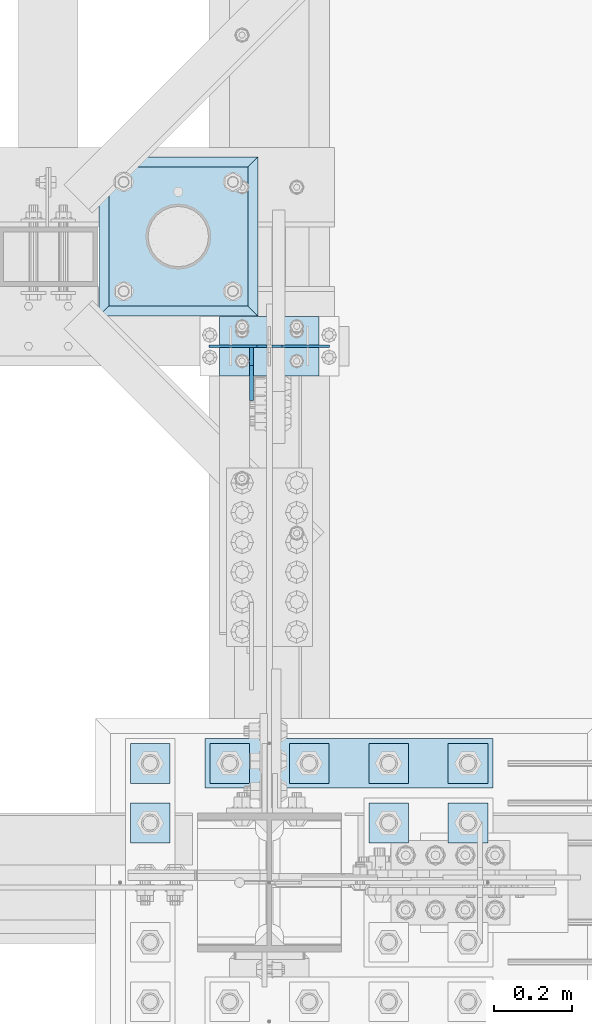
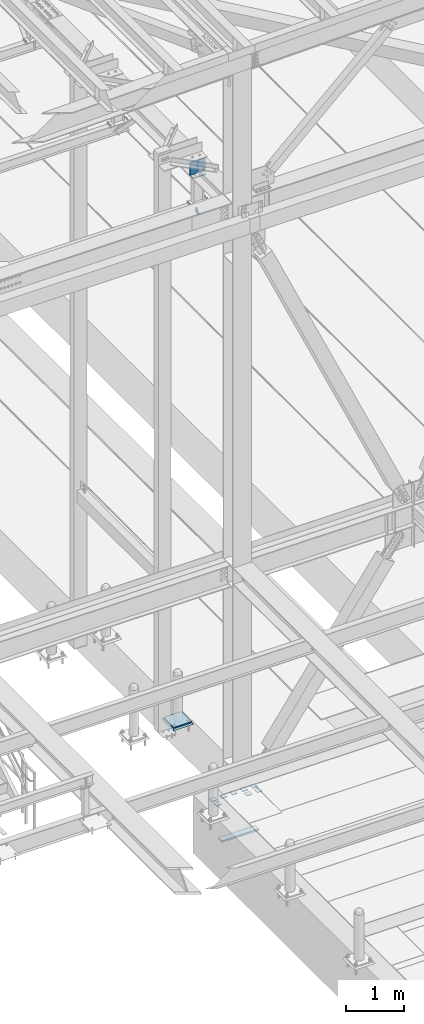
# One storey, part 3035 of 3843: 15 plates, 6 elements without a shape of their own.
"""IFC2X3 building model written with IfcOpenShell, lengths in millimetres."""

from ifc_helpers import new_model, si_unit, frame, origin_with_axes, place, context, subcontext, project, spatial, faceted_brep, material, type_object, element, aggregate, save


model = new_model("IFC2X3")

# Units and contexts
model_context = context("Model", 3, precision=1e-05, world=origin_with_axes())
body_context = subcontext(model_context, "Body", "Model", "MODEL_VIEW")
ifc_project = project(units=[si_unit("LENGTHUNIT", "METRE", prefix="MILLI"), si_unit("AREAUNIT", "SQUARE_METRE"), si_unit("VOLUMEUNIT", "CUBIC_METRE"), si_unit("MASSUNIT", "GRAM", prefix="KILO"), si_unit("TIMEUNIT", "SECOND"), si_unit("PLANEANGLEUNIT", "RADIAN"), si_unit("SOLIDANGLEUNIT", "STERADIAN"), si_unit("THERMODYNAMICTEMPERATUREUNIT", "DEGREE_CELSIUS"), si_unit("LUMINOUSINTENSITYUNIT", "LUMEN")], contexts=[model_context])

# Site, building, storey
site_placement = place(None, origin_with_axes())
site = spatial("IfcSite", under=ifc_project, at=site_placement, CompositionType="ELEMENT")
building_placement = place(site_placement, origin_with_axes())
building = spatial("IfcBuilding", under=site, at=building_placement, Name="Undefined", CompositionType="ELEMENT")
storey_placement = place(building_placement, origin_with_axes())
storey = spatial("IfcBuildingStorey", under=building, at=storey_placement, Name="Undefined", CompositionType="ELEMENT", Elevation=0.0)

# Assembly, plate
assembly_1_placement = place(storey_placement, origin_with_axes())
assembly_1 = element("IfcElementAssembly", 1, at=assembly_1_placement, inside=storey, Name="PIPE_BOLLARD", AssemblyPlace="NOTDEFINED", PredefinedType="RIGID_FRAME")
ifc_material_1 = material(Name="STEEL/A572-50")
plate_type_1 = type_object("IfcPlateType", PredefinedType="NOTDEFINED")
plate_1_placement = place(assembly_1_placement, frame((41651.6014282227, 27089.8153033043, 30518.1), z_axis=(0.0, 1.0, 0.0), x_axis=(1.0, 0.0, 0.0)))
plate_1 = element("IfcPlate", 2, at=plate_1_placement, type_object=plate_type_1, material=ifc_material_1, Name="PLATE", context=body_context, shape_type="Brep", body=[
    faceted_brep([(0.0, -12.6999999999971, 0.0), (0.0, -12.7000000000007, 355.600000000006), (0.0, 12.7000000000007, 355.600000000006), (0.0, 12.6999999999971, 0.0), (355.599999999999, -12.7000000000007, 355.600000000006), (355.599999999999, 12.7000000000007, 355.600000000006), (355.599999999999, -12.7000000000007, 0.0), (355.599999999999, 12.7000000000007, 0.0)], [[[0, 1, 2, 3]], [[1, 4, 5, 2]], [[4, 6, 7, 5]], [[6, 0, 3, 7]], [[5, 7, 3, 2]], [[6, 4, 1, 0]]]),
])
aggregate(assembly_1, [plate_1])

assembly_2_placement = place(storey_placement, origin_with_axes())
assembly_2 = element("IfcElementAssembly", 3, at=assembly_2_placement, inside=storey, Name="GROUT", AssemblyPlace="NOTDEFINED", PredefinedType="REINFORCEMENT_UNIT")
ifc_material_2 = material(Name="CONCRETE/Concrete_Undefined")
plate_type_2 = type_object("IfcPlateType", PredefinedType="NOTDEFINED")
plate_2_placement = place(assembly_2_placement, frame((41626.2014282227, 27064.4153033043, 30492.7), z_axis=(0.0, 1.0, 0.0), x_axis=(1.0, 0.0, 0.0)))
plate_2 = element("IfcPlate", 4, at=plate_2_placement, type_object=plate_type_2, material=ifc_material_2, Name="GROUT", context=body_context, shape_type="Brep", body=[
    faceted_brep([(25.4000000001906, -12.6999999998552, 380.999999999505), (0.0, 12.7000000000007, 406.399999999994), (0.0, 12.6999999999971, 0.0), (25.4000000001906, -12.6999999999898, 25.4000000004453), (380.999999999833, -12.6999999998588, 25.4000000004453), (406.400000000001, 12.7000000000007, 0.0), (406.400000000001, 12.7000000000007, 406.399999999994), (380.999999999833, -12.6999999999898, 380.999999999505)], [[[0, 1, 2, 3]], [[4, 5, 6, 7]], [[4, 7, 0, 3]], [[5, 4, 3, 2]], [[6, 5, 2, 1]], [[7, 6, 1, 0]]]),
])
aggregate(assembly_2, [plate_2])

assembly_3_placement = place(storey_placement, origin_with_axes())
assembly_3 = element("IfcElementAssembly", 5, at=assembly_3_placement, inside=storey, Name="POST", AssemblyPlace="NOTDEFINED", PredefinedType="RIGID_FRAME")
plate_type_3 = type_object("IfcPlateType", PredefinedType="NOTDEFINED")
plate_3_placement = place(assembly_3_placement, frame((41935.3999970689, 27063.7030619311, 42079.8625004935), z_axis=(0.0, -0.999999948197597, -0.000321877000061539), x_axis=(1.0, 0.0, 0.0)))
plate_3 = element("IfcPlate", 6, at=plate_3_placement, type_object=plate_type_3, material=ifc_material_1, Name="PLATE", context=body_context, shape_type="Brep", body=[
    faceted_brep([(0.0, -9.52500000000146, 0.0), (0.0, -9.5249999999287, 152.40000000162), (0.0, 9.52500000002328, 152.40000000162), (0.0, 9.52500000000146, 0.0), (254.0, -9.5249999999287, 152.40000000162), (254.0, 9.52500000002328, 152.40000000162), (253.999999999998, -9.52500000000146, 0.0), (253.999999999998, 9.52500000000146, 0.0)], [[[0, 1, 2, 3]], [[1, 4, 5, 2]], [[4, 6, 7, 5]], [[6, 0, 3, 7]], [[5, 7, 3, 2]], [[6, 4, 1, 0]]]),
])
aggregate(assembly_3, [plate_3])

# Assembly, plates
assembly_4_placement = place(storey_placement, origin_with_axes())
assembly_4 = element("IfcElementAssembly", 7, at=assembly_4_placement, inside=storey, Name="TEMPLATE", AssemblyPlace="NOTDEFINED", PredefinedType="RIGID_FRAME")
plate_type_4 = type_object("IfcPlateType", PredefinedType="NOTDEFINED")
plate_4_placement = place(assembly_4_placement, frame((41808.4, 25819.1, 29686.25), z_axis=(-1.0, 0.0, 0.0), x_axis=(0.0, -1.0, 0.0)))
plate_4 = element("IfcPlate", 8, at=plate_4_placement, type_object=plate_type_4, material=ifc_material_1, Name="Washer Plate", context=body_context, shape_type="Brep", body=[
    faceted_brep([(0.0, -6.3499999046162, 0.0), (-1.67347025126219e-10, -6.35000000000582, 101.600000000151), (-1.67347025126219e-10, 6.35000000000582, 101.600000000151), (7.27595761418343e-12, 6.3499999046162, 0.0), (101.599998474121, -6.34999999999854, 101.599998474121), (101.599998474121, 6.34999999999854, 101.599998474121), (101.6, -6.34999999999854, 0.0), (101.6, 6.34999999999854, 0.0)], [[[0, 1, 2, 3]], [[1, 4, 5, 2]], [[4, 6, 7, 5]], [[6, 0, 3, 7]], [[5, 7, 3, 2]], [[6, 4, 1, 0]]]),
])
plate_5_placement = place(assembly_4_placement, frame((42418.0, 25819.1, 29686.25), z_axis=(-1.0, 0.0, 0.0), x_axis=(0.0, -1.0, 0.0)))
plate_5 = element("IfcPlate", 9, at=plate_5_placement, type_object=plate_type_4, material=ifc_material_1, Name="Washer Plate", context=body_context, shape_type="Brep", body=[
    faceted_brep([(0.0, -6.3499999046162, 0.0), (-1.67347025126219e-10, -6.35000000000582, 101.600000000151), (-1.67347025126219e-10, 6.35000000000582, 101.600000000151), (7.27595761418343e-12, 6.3499999046162, 0.0), (101.599998474121, -6.34999999999854, 101.599998474121), (101.599998474121, 6.34999999999854, 101.599998474121), (101.6, -6.34999999999854, 0.0), (101.6, 6.34999999999854, 0.0)], [[[0, 1, 2, 3]], [[1, 4, 5, 2]], [[4, 6, 7, 5]], [[6, 0, 3, 7]], [[5, 7, 3, 2]], [[6, 4, 1, 0]]]),
])
plate_6_placement = place(assembly_4_placement, frame((42621.2, 25819.1, 29686.25), z_axis=(-1.0, 0.0, 0.0), x_axis=(0.0, -1.0, 0.0)))
plate_6 = element("IfcPlate", 10, at=plate_6_placement, type_object=plate_type_4, material=ifc_material_1, Name="Washer Plate", context=body_context, shape_type="Brep", body=[
    faceted_brep([(0.0, -6.3499999046162, 0.0), (-1.67347025126219e-10, -6.35000000000582, 101.600000000151), (-1.67347025126219e-10, 6.35000000000582, 101.600000000151), (7.27595761418343e-12, 6.3499999046162, 0.0), (101.599998474121, -6.34999999999854, 101.599998474121), (101.599998474121, 6.34999999999854, 101.599998474121), (101.6, -6.34999999999854, 0.0), (101.6, 6.34999999999854, 0.0)], [[[0, 1, 2, 3]], [[1, 4, 5, 2]], [[4, 6, 7, 5]], [[6, 0, 3, 7]], [[5, 7, 3, 2]], [[6, 4, 1, 0]]]),
])
plate_7_placement = place(assembly_4_placement, frame((41808.4, 25971.5, 29686.25), z_axis=(-1.0, 0.0, 0.0), x_axis=(0.0, -1.0, 0.0)))
plate_7 = element("IfcPlate", 11, at=plate_7_placement, type_object=plate_type_4, material=ifc_material_1, Name="Washer Plate", context=body_context, shape_type="Brep", body=[
    faceted_brep([(0.0, -6.3499999046162, 0.0), (-1.67347025126219e-10, -6.35000000000582, 101.600000000151), (-1.67347025126219e-10, 6.35000000000582, 101.600000000151), (7.27595761418343e-12, 6.3499999046162, 0.0), (101.599998474121, -6.34999999999854, 101.599998474121), (101.599998474121, 6.34999999999854, 101.599998474121), (101.6, -6.34999999999854, 0.0), (101.6, 6.34999999999854, 0.0)], [[[0, 1, 2, 3]], [[1, 4, 5, 2]], [[4, 6, 7, 5]], [[6, 0, 3, 7]], [[5, 7, 3, 2]], [[6, 4, 1, 0]]]),
])
plate_8_placement = place(assembly_4_placement, frame((42011.6, 25971.5, 29686.25), z_axis=(-1.0, 0.0, 0.0), x_axis=(0.0, -1.0, 0.0)))
plate_8 = element("IfcPlate", 12, at=plate_8_placement, type_object=plate_type_4, material=ifc_material_1, Name="Washer Plate", context=body_context, shape_type="Brep", body=[
    faceted_brep([(0.0, -6.3499999046162, 0.0), (-1.67347025126219e-10, -6.35000000000582, 101.600000000151), (-1.67347025126219e-10, 6.35000000000582, 101.600000000151), (7.27595761418343e-12, 6.3499999046162, 0.0), (101.599998474121, -6.34999999999854, 101.599998474121), (101.599998474121, 6.34999999999854, 101.599998474121), (101.6, -6.34999999999854, 0.0), (101.6, 6.34999999999854, 0.0)], [[[0, 1, 2, 3]], [[1, 4, 5, 2]], [[4, 6, 7, 5]], [[6, 0, 3, 7]], [[5, 7, 3, 2]], [[6, 4, 1, 0]]]),
])
plate_9_placement = place(assembly_4_placement, frame((42214.8, 25971.5, 29686.25), z_axis=(-1.0, 0.0, 0.0), x_axis=(0.0, -1.0, 0.0)))
plate_9 = element("IfcPlate", 13, at=plate_9_placement, type_object=plate_type_4, material=ifc_material_1, Name="Washer Plate", context=body_context, shape_type="Brep", body=[
    faceted_brep([(0.0, -6.3499999046162, 0.0), (-1.67347025126219e-10, -6.35000000000582, 101.600000000151), (-1.67347025126219e-10, 6.35000000000582, 101.600000000151), (7.27595761418343e-12, 6.3499999046162, 0.0), (101.599998474121, -6.34999999999854, 101.599998474121), (101.599998474121, 6.34999999999854, 101.599998474121), (101.6, -6.34999999999854, 0.0), (101.6, 6.34999999999854, 0.0)], [[[0, 1, 2, 3]], [[1, 4, 5, 2]], [[4, 6, 7, 5]], [[6, 0, 3, 7]], [[5, 7, 3, 2]], [[6, 4, 1, 0]]]),
])
plate_10_placement = place(assembly_4_placement, frame((42418.0, 25971.5, 29686.25), z_axis=(-1.0, 0.0, 0.0), x_axis=(0.0, -1.0, 0.0)))
plate_10 = element("IfcPlate", 14, at=plate_10_placement, type_object=plate_type_4, material=ifc_material_1, Name="Washer Plate", context=body_context, shape_type="Brep", body=[
    faceted_brep([(0.0, -6.3499999046162, 0.0), (-1.67347025126219e-10, -6.35000000000582, 101.600000000151), (-1.67347025126219e-10, 6.35000000000582, 101.600000000151), (7.27595761418343e-12, 6.3499999046162, 0.0), (101.599998474121, -6.34999999999854, 101.599998474121), (101.599998474121, 6.34999999999854, 101.599998474121), (101.6, -6.34999999999854, 0.0), (101.6, 6.34999999999854, 0.0)], [[[0, 1, 2, 3]], [[1, 4, 5, 2]], [[4, 6, 7, 5]], [[6, 0, 3, 7]], [[5, 7, 3, 2]], [[6, 4, 1, 0]]]),
])
plate_11_placement = place(assembly_4_placement, frame((42621.2, 25971.5, 29686.25), z_axis=(-1.0, 0.0, 0.0), x_axis=(0.0, -1.0, 0.0)))
plate_11 = element("IfcPlate", 15, at=plate_11_placement, type_object=plate_type_4, material=ifc_material_1, Name="Washer Plate", context=body_context, shape_type="Brep", body=[
    faceted_brep([(0.0, -6.3499999046162, 0.0), (-1.67347025126219e-10, -6.35000000000582, 101.600000000151), (-1.67347025126219e-10, 6.35000000000582, 101.600000000151), (7.27595761418343e-12, 6.3499999046162, 0.0), (101.599998474121, -6.34999999999854, 101.599998474121), (101.599998474121, 6.34999999999854, 101.599998474121), (101.6, -6.34999999999854, 0.0), (101.6, 6.34999999999854, 0.0)], [[[0, 1, 2, 3]], [[1, 4, 5, 2]], [[4, 6, 7, 5]], [[6, 0, 3, 7]], [[5, 7, 3, 2]], [[6, 4, 1, 0]]]),
])

# Assembly, plate
assembly_5_placement = place(storey_placement, origin_with_axes())
assembly_5 = element("IfcElementAssembly", 16, at=assembly_5_placement, inside=storey, Name="BEAM", AssemblyPlace="NOTDEFINED", PredefinedType="RIGID_FRAME")
plate_type_5 = type_object("IfcPlateType", PredefinedType="NOTDEFINED")
plate_12_placement = place(assembly_5_placement, frame((42016.3625, 26984.3250000347, 41306.750000025), z_axis=(0.0, -1.0, 0.0), x_axis=(0.0, 0.0, 1.0)))
plate_12 = element("IfcPlate", 17, at=plate_12_placement, type_object=plate_type_5, material=ifc_material_1, Name="PLATE", context=body_context, shape_type="Brep", body=[
    faceted_brep([(0.0, -4.76250000000073, 12.6999998092651), (4.450703272596e-08, -4.76249999999709, 93.0710244828806), (4.450703272596e-08, 4.76249999999709, 93.0710244828806), (0.0, 4.76250000000073, 12.6999998092651), (43.3137807601452, -4.76249999999709, 136.384805065652), (43.3137807601452, 4.76249999999709, 136.384805065652), (133.209805202001, -4.76249999999709, 46.4887805392646), (133.209805202001, 4.76249999999709, 46.4887805392646), (86.7210245267561, -4.76249999999709, 0.0), (86.7210245267561, 4.76249999999709, 0.0), (12.6999998092651, -4.76250000000073, 0.0), (12.6999998092651, 4.76250000000073, 0.0)], [[[0, 1, 2, 3]], [[1, 4, 5, 2]], [[4, 6, 7, 5]], [[6, 8, 9, 7]], [[8, 10, 11, 9]], [[10, 0, 3, 11]], [[5, 7, 9, 11, 3, 2]], [[10, 8, 6, 4, 1, 0]]]),
])
aggregate(assembly_5, [plate_12])

# Assembly, plates
assembly_6_placement = place(storey_placement, origin_with_axes())
assembly_6 = element("IfcElementAssembly", 18, at=assembly_6_placement, inside=storey, Name="BEAM", AssemblyPlace="NOTDEFINED", PredefinedType="RIGID_FRAME")
plate_type_6 = type_object("IfcPlateType", PredefinedType="NOTDEFINED")
plate_13_placement = place(assembly_6_placement, frame((42216.3875, 26987.4054687485, 42383.516460589), z_axis=(0.0, 0.000321877000067616, -0.999999948197597), x_axis=(-1.0, 0.0, 0.0)))
plate_13 = element("IfcPlate", 19, at=plate_13_placement, type_object=plate_type_6, material=ifc_material_1, Name="PLATE", context=body_context, shape_type="Brep", body=[
    faceted_brep([(0.0, -3.17499999999927, 0.0), (0.0, -3.17500000007567, 273.049999997937), (0.0, 3.17499999993743, 273.049999997937), (0.0, 3.17499999999927, 0.0), (122.237500389827, -3.17500000007567, 273.049999997937), (122.237500389827, 3.17499999993743, 273.049999997937), (147.637500008357, -3.17500000006476, 247.650000379464), (147.637500008357, 3.17499999994106, 247.650000379464), (147.637500008357, -3.17500000001382, 25.3999996184648), (147.637500008357, 3.17499999999927, 25.3999996184648), (122.237500389827, -3.17500000000291, 0.0), (122.237500389827, 3.17500000000291, -7.27595761418343e-12)], [[[0, 1, 2, 3]], [[1, 4, 5, 2]], [[4, 6, 7, 5]], [[6, 8, 9, 7]], [[8, 10, 11, 9]], [[10, 0, 3, 11]], [[5, 7, 9, 11, 3, 2]], [[10, 8, 6, 4, 1, 0]]]),
])
plate_14_placement = place(assembly_6_placement, frame((41908.4125, 26987.4054687485, 42383.516460589), z_axis=(0.0, 0.000321877000067616, -0.999999948197597), x_axis=(1.0, 0.0, 0.0)))
plate_14 = element("IfcPlate", 20, at=plate_14_placement, type_object=plate_type_6, material=ifc_material_1, Name="PLATE", context=body_context, shape_type="Brep", body=[
    faceted_brep([(0.0, -3.17499999999927, 0.0), (0.0, -3.17500000007567, 273.049999997937), (0.0, 3.17499999993743, 273.049999997937), (0.0, 3.17499999999927, 0.0), (122.237500389827, -3.17500000007567, 273.049999997937), (122.237500389827, 3.17499999993743, 273.049999997937), (147.637500008357, -3.17500000006476, 247.650000379464), (147.637500008357, 3.17499999994106, 247.650000379464), (147.637500008357, -3.17500000001382, 25.3999996184648), (147.637500008357, 3.17499999999927, 25.3999996184648), (122.237500389827, -3.17500000000291, 0.0), (122.237500389827, 3.17500000000291, -7.27595761418343e-12)], [[[0, 1, 2, 3]], [[1, 4, 5, 2]], [[4, 6, 7, 5]], [[6, 8, 9, 7]], [[8, 10, 11, 9]], [[10, 0, 3, 11]], [[5, 7, 9, 11, 3, 2]], [[10, 8, 6, 4, 1, 0]]]),
])
aggregate(assembly_6, [plate_13, plate_14])

# Plate
plate_type_7 = type_object("IfcPlateType", PredefinedType="NOTDEFINED")
plate_15_placement = place(assembly_4_placement, frame((41897.3, 25984.2, 28784.55), z_axis=(1.0, 0.0, 0.0), x_axis=(0.0, -1.0, 0.0)))
plate_15 = element("IfcPlate", 21, at=plate_15_placement, type_object=plate_type_7, material=ifc_material_1, Name="PLATE", context=body_context, shape_type="Brep", body=[
    faceted_brep([(0.0, -19.0500000000029, 0.0), (0.0, -19.0499999999993, 736.600036621094), (0.0, 19.0499999999993, 736.600036621094), (0.0, 19.0500000000029, 0.0), (127.0, -19.0499999999993, 736.600036621094), (127.0, 19.0499999999993, 736.600036621094), (127.0, -19.0499999999993, 0.0), (127.0, 19.0499999999993, 0.0)], [[[0, 1, 2, 3]], [[1, 4, 5, 2]], [[4, 6, 7, 5]], [[6, 0, 3, 7]], [[5, 7, 3, 2]], [[6, 4, 1, 0]]]),
])

aggregate(assembly_4, [plate_15, plate_4, plate_5, plate_6, plate_7, plate_8, plate_9, plate_10, plate_11])

save(model, "model.ifc")
